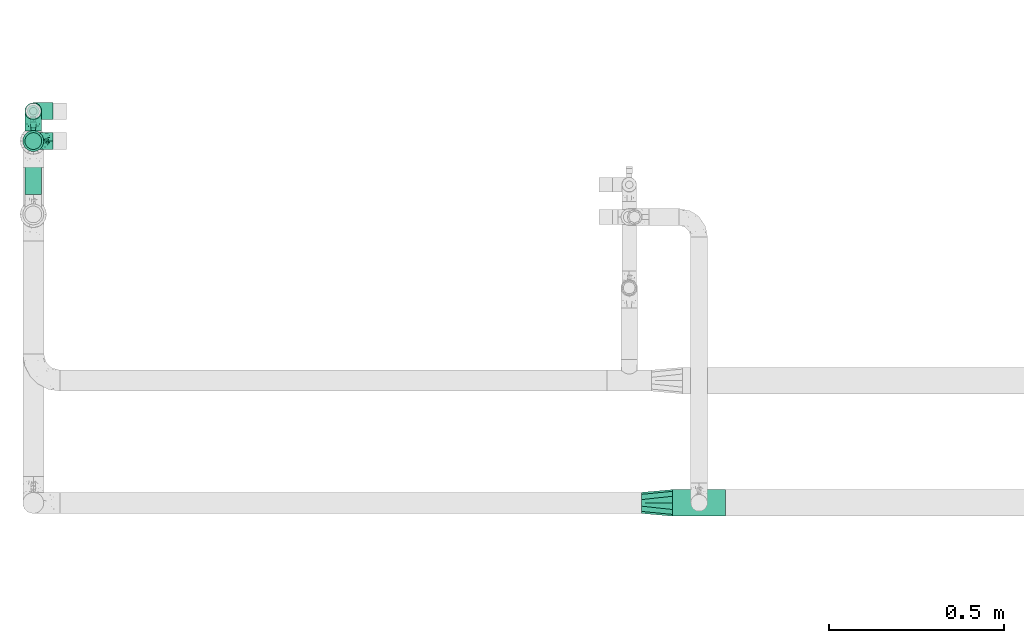
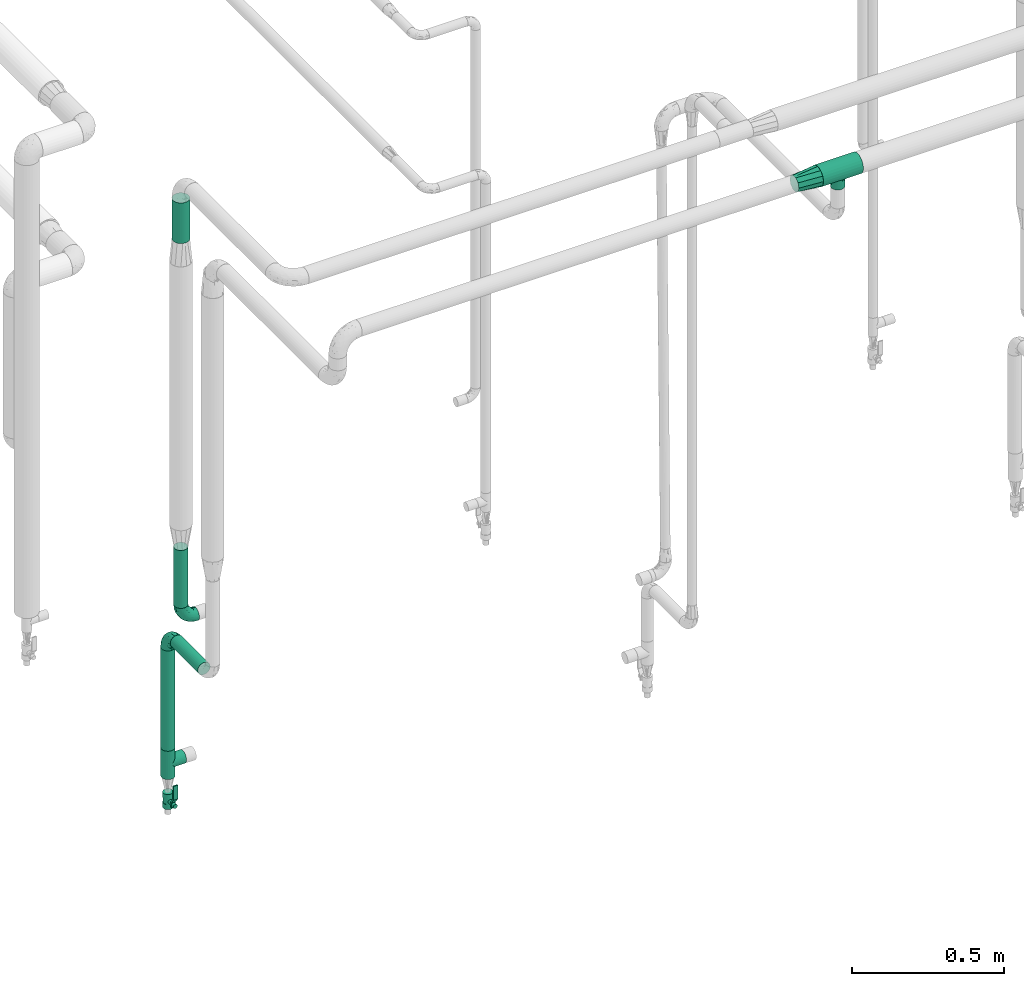
# One storey, part 566 of 827: 5 flow fittings, 4 flow segments, 1 flow controller.
"""IFC2X3 building model written with IfcOpenShell, lengths in millimetres."""

from ifc_helpers import new_model, entity, si_unit, converted_unit, derived_unit, direction, frame, origin, origin_2d_with_axis, place, context, subcontext, project, spatial, polyline, circle, outline, extrude, faceted_brep, source, transform, mapped, material, material_list, type_object, type_shapes, element, save


model = new_model("IFC2X3")

# Units and contexts
model_context = context("Model", 3, precision=0.01, world=origin(), true_north=direction((6.12303176911189e-17, 1.0)))
body_context = subcontext(model_context, "Body", "Model", "MODEL_VIEW")
ifc_project = project(units=[si_unit("LENGTHUNIT", "METRE", prefix="MILLI"), si_unit("AREAUNIT", "SQUARE_METRE"), si_unit("VOLUMEUNIT", "CUBIC_METRE"), converted_unit("PLANEANGLEUNIT", "DEGREE", entity("IfcRatioMeasure", 0.0174532925199433), si_unit("PLANEANGLEUNIT", "RADIAN"), dimensions=[0, 0, 0, 0, 0, 0, 0]), si_unit("MASSUNIT", "GRAM", prefix="KILO"), derived_unit("MASSDENSITYUNIT", [(si_unit("MASSUNIT", "GRAM", prefix="KILO"), 1), (si_unit("LENGTHUNIT", "METRE"), -3)]), derived_unit("MOMENTOFINERTIAUNIT", [(si_unit("LENGTHUNIT", "METRE"), 4)]), si_unit("TIMEUNIT", "SECOND"), si_unit("FREQUENCYUNIT", "HERTZ"), si_unit("THERMODYNAMICTEMPERATUREUNIT", "DEGREE_CELSIUS"), derived_unit("THERMALTRANSMITTANCEUNIT", [(si_unit("MASSUNIT", "GRAM", prefix="KILO"), 1), (si_unit("THERMODYNAMICTEMPERATUREUNIT", "KELVIN"), -1), (si_unit("TIMEUNIT", "SECOND"), -3)]), derived_unit("VOLUMETRICFLOWRATEUNIT", [(si_unit("LENGTHUNIT", "METRE"), 3), (si_unit("TIMEUNIT", "SECOND"), -1)]), derived_unit("MASSFLOWRATEUNIT", [(si_unit("MASSUNIT", "GRAM", prefix="KILO"), 1), (si_unit("TIMEUNIT", "SECOND"), -1)]), derived_unit("ROTATIONALFREQUENCYUNIT", [(si_unit("TIMEUNIT", "SECOND"), -1)]), si_unit("ELECTRICCURRENTUNIT", "AMPERE"), si_unit("ELECTRICVOLTAGEUNIT", "VOLT"), si_unit("POWERUNIT", "WATT"), si_unit("FORCEUNIT", "NEWTON", prefix="KILO"), si_unit("ILLUMINANCEUNIT", "LUX"), si_unit("LUMINOUSFLUXUNIT", "LUMEN"), si_unit("LUMINOUSINTENSITYUNIT", "CANDELA"), derived_unit("USERDEFINED", [(si_unit("MASSUNIT", "GRAM", prefix="KILO"), -1), (si_unit("LENGTHUNIT", "METRE"), -2), (si_unit("TIMEUNIT", "SECOND"), 3), (si_unit("LUMINOUSFLUXUNIT", "LUMEN"), 1)]), derived_unit("LINEARVELOCITYUNIT", [(si_unit("LENGTHUNIT", "METRE"), 1), (si_unit("TIMEUNIT", "SECOND"), -1)]), si_unit("PRESSUREUNIT", "PASCAL"), derived_unit("USERDEFINED", [(si_unit("LENGTHUNIT", "METRE"), -2), (si_unit("MASSUNIT", "GRAM", prefix="KILO"), 1), (si_unit("TIMEUNIT", "SECOND"), -2)]), derived_unit("LINEARFORCEUNIT", [(si_unit("MASSUNIT", "GRAM", prefix="KILO"), 1), (si_unit("LENGTHUNIT", "METRE"), 1), (si_unit("TIMEUNIT", "SECOND"), -2), (si_unit("LENGTHUNIT", "METRE"), -1)]), derived_unit("PLANARFORCEUNIT", [(si_unit("MASSUNIT", "GRAM", prefix="KILO"), 1), (si_unit("LENGTHUNIT", "METRE"), 1), (si_unit("TIMEUNIT", "SECOND"), -2), (si_unit("LENGTHUNIT", "METRE"), -2)])], contexts=[model_context])

# Site, building, storey
site_placement = place(None, origin())
site = spatial("IfcSite", under=ifc_project, at=site_placement, CompositionType="ELEMENT")
building_placement = place(site_placement, origin())
building = spatial("IfcBuilding", under=site, at=building_placement, CompositionType="ELEMENT")
storey_placement = place(building_placement, frame((0.0, 0.0, 28200.0)))
storey = spatial("IfcBuildingStorey", under=building, at=storey_placement, Name="08", CompositionType="ELEMENT", Elevation=28200.0)

# Flow segments
pipe_segment_type = type_object("IfcPipeSegmentType", PredefinedType="NOTDEFINED")
flow_segment_1_placement = place(storey_placement, frame((11725.36, 15495.26, 459.5)))
element("IfcFlowSegment", 1, at=flow_segment_1_placement, inside=storey, type_object=pipe_segment_type, context=body_context, shape_type="SweptSolid", body=[
    extrude(circle(Radius=24.0, at=origin_2d_with_axis()), frame((25.6, 25.6, 0.0), z_axis=(0.0, 0.0, 1.0), x_axis=(-1.0, 0.0, 0.0)), (0.0, 0.0, 1.0), 404.113920389359),
])
flow_segment_2_placement = place(storey_placement, frame((11725.36, 15282.4, 895.02)))
element("IfcFlowSegment", 2, at=flow_segment_2_placement, inside=storey, type_object=pipe_segment_type, context=body_context, shape_type="SweptSolid", body=[
    extrude(circle(Radius=24.0, at=origin_2d_with_axis()), frame((25.6, 0.0, 25.6), z_axis=(0.0, 1.0, 0.0), x_axis=(-1.0, 0.0, 0.0)), (0.0, 0.0, 1.0), 181.457119084471),
])
flow_segment_3_placement = place(storey_placement, frame((11725.36, 15409.61, 1087.0)))
element("IfcFlowSegment", 3, at=flow_segment_3_placement, inside=storey, type_object=pipe_segment_type, context=body_context, shape_type="SweptSolid", body=[
    extrude(circle(Radius=24.0, at=origin_2d_with_axis()), frame((25.6, 25.6, 0.0), z_axis=(0.0, 0.0, 1.0), x_axis=(-1.0, 0.0, 0.0)), (0.0, 0.0, 1.0), 233.163831722912),
])
flow_segment_4_placement = place(storey_placement, frame((11719.36, 15403.61, 2560.7)))
element("IfcFlowSegment", 4, at=flow_segment_4_placement, inside=storey, type_object=pipe_segment_type, context=body_context, shape_type="SweptSolid", body=[
    extrude(circle(Radius=30.0, at=origin_2d_with_axis()), frame((31.6, 31.6, 0.0)), (0.0, 0.0, 1.0), 163.304800928467),
])

# Flow controller
ifc_material = material()
ifc_material_list = material_list([ifc_material, ifc_material, ifc_material, ifc_material, ifc_material])
valve_type = type_object("IfcValveType", PredefinedType="NOTDEFINED", material=ifc_material_list)
shared_shape_1 = source(origin(), body_context, "Body", "SweptSolid", [
    extrude(circle(Radius=17.5, at=origin_2d_with_axis()), frame((-30.5, 0.0, 0.0), z_axis=(1.0, 0.0, 0.0), x_axis=(0.0, 1.0, 0.0)), (0.0, 0.0, 1.0), 20.3333333333333),
    extrude(circle(Radius=16.0, at=origin_2d_with_axis()), frame((-10.17, 0.0, 0.0), z_axis=(1.0, 0.0, 0.0), x_axis=(0.0, 1.0, 0.0)), (0.0, 0.0, 1.0), 20.3333333333333),
    extrude(circle(Radius=17.5, at=origin_2d_with_axis()), frame((10.17, 0.0, 0.0), z_axis=(1.0, 0.0, 0.0), x_axis=(0.0, 1.0, 0.0)), (0.0, 0.0, 1.0), 20.3333333333333),
    extrude(outline(polyline([(-38.75, -5.0), (-38.75, -10.0), (-17.92, -10.0), (2.08, 5.0), (56.25, 5.0), (56.25, 10.0), (0.42, 10.0), (-19.58, -5.0), (-38.75, -5.0)])), frame((28.75, -8.75, 41.5), z_axis=(0.0, -1.0, 0.0), x_axis=(1.0, 0.0, 0.0)), (0.0, 0.0, -1.0), 17.5),
    extrude(circle(Radius=8.0, at=origin_2d_with_axis()), origin(), (0.0, 0.0, 1.0), 49.0),
])
type_shapes(valve_type, [shared_shape_1])
flow_controller_placement = place(storey_placement, frame((11750.95, 15520.86, 250.0), z_axis=(0.0, -1.0, 0.0), x_axis=(0.0, 0.0, 1.0)))
element("IfcFlowController", 5, at=flow_controller_placement, inside=storey, type_object=valve_type, material=ifc_material, context=body_context, shape_type="MappedRepresentation", body=[
    mapped(shared_shape_1, transform((0.0, 0.0, 0.0), scale=1.0)),
])

# Flow fittings
pipe_fitting_type_1 = type_object("IfcPipeFittingType", Name="ADSK_1", PredefinedType="NOTDEFINED", material=ifc_material)
shared_shape_2 = source(origin(), body_context, "Body", "Brep", [
    faceted_brep([(-76.0, 9.85, -36.75), (-76.0, 0.0, -38.05), (-76.0, -9.85, -36.75), (-76.0, -19.03, -32.95), (-76.0, -26.91, -26.91), (-76.0, -32.95, -19.03), (-76.0, -36.75, -9.85), (-76.0, -38.05, 0.0), (-76.0, -36.75, 9.85), (-76.0, -32.95, 19.02), (-76.0, -26.91, 26.91), (-76.0, -19.03, 32.95), (-76.0, -9.85, 36.75), (-76.0, 0.0, 38.05), (-76.0, 9.85, 36.75), (-76.0, 19.02, 32.95), (-76.0, 26.91, 26.91), (-76.0, 32.95, 19.02), (-76.0, 36.75, 9.85), (-76.0, 38.05, 0.0), (-76.0, 36.75, -9.85), (-76.0, 32.95, -19.03), (-76.0, 26.91, -26.91), (-76.0, 19.02, -32.95), (76.0, 26.91, -26.91), (76.0, 32.95, -19.03), (76.0, 36.75, -9.85), (76.0, 38.05, 0.0), (76.0, 36.75, 9.85), (76.0, 32.95, 19.02), (76.0, 26.91, 26.91), (76.0, 19.02, 32.95), (76.0, 9.85, 36.75), (76.0, 0.0, 38.05), (76.0, -9.85, 36.75), (76.0, -19.03, 32.95), (76.0, -26.91, 26.91), (76.0, -32.95, 19.02), (76.0, -36.75, 9.85), (76.0, -38.05, 0.0), (76.0, -36.75, -9.85), (76.0, -32.95, -19.03), (76.0, -26.91, -26.91), (76.0, -19.03, -32.95), (76.0, -9.85, -36.75), (76.0, 0.0, -38.05), (76.0, 9.85, -36.75), (76.0, 19.02, -32.95), (22.62, -37.1, 8.45), (23.39, -37.58, 4.22), (24.15, -38.05, 0.0), (18.42, -34.7, 15.61), (4.31, -29.72, 23.76), (12.18, -31.83, 20.86), (8.24, -30.77, 22.31), (-24.15, -38.05, 0.0), (-23.39, -37.58, 4.22), (-22.63, -37.1, 8.44), (-18.43, -34.7, 15.61), (-12.18, -31.83, 20.85), (-4.31, -29.72, 23.76), (0.0, -29.72, 23.76), (4.31, -29.72, -23.76), (12.18, -31.83, -20.86), (8.24, -30.77, -22.31), (18.42, -34.7, -15.61), (22.62, -37.1, -8.45), (23.39, -37.58, -4.22), (-4.31, -29.72, -23.76), (-12.18, -31.83, -20.85), (-18.43, -34.7, -15.61), (0.0, -29.72, -23.76), (-22.63, -37.1, -8.44), (-23.39, -37.58, -4.22), (0.0, -67.0, -24.15), (6.25, -67.0, -23.33), (12.08, -67.0, -20.91), (17.08, -67.0, -17.08), (20.91, -67.0, -12.08), (23.33, -67.0, -6.25), (24.15, -67.0, 0.0), (23.33, -67.0, 6.25), (20.91, -67.0, 12.07), (17.08, -67.0, 17.08), (12.08, -67.0, 20.91), (6.25, -67.0, 23.33), (0.0, -67.0, 24.15), (-6.25, -67.0, 23.33), (-12.07, -67.0, 20.91), (-17.08, -67.0, 17.08), (-20.91, -67.0, 12.07), (-23.33, -67.0, 6.25), (-24.15, -67.0, 0.0), (-23.33, -67.0, -6.25), (-20.91, -67.0, -12.08), (-17.08, -67.0, -17.08), (-12.07, -67.0, -20.91), (-6.25, -67.0, -23.33)], [[[0, 1, 2, 3, 4, 5, 6, 7, 8, 9, 10, 11, 12, 13, 14, 15, 16, 17, 18, 19, 20, 21, 22, 23]], [[24, 25, 26, 27, 28, 29, 30, 31, 32, 33, 34, 35, 36, 37, 38, 39, 40, 41, 42, 43, 44, 45, 46, 47]], [[39, 38, 48]], [[39, 48, 49, 50]], [[38, 51, 48]], [[37, 36, 52]], [[53, 51, 37]], [[37, 52, 54, 53]], [[36, 10, 52]], [[37, 51, 38]], [[7, 55, 56, 57]], [[8, 7, 57]], [[57, 58, 8]], [[59, 60, 9]], [[59, 9, 58]], [[9, 60, 10]], [[58, 9, 8]], [[10, 60, 61, 52]], [[36, 35, 11, 10]], [[13, 12, 34, 33]], [[12, 11, 35, 34]], [[14, 13, 33, 32]], [[29, 28, 18, 17]], [[16, 15, 31, 30]], [[17, 16, 30, 29]], [[32, 31, 15, 14]], [[19, 18, 28, 27]], [[26, 25, 21, 20]], [[25, 24, 22, 21]], [[27, 26, 20, 19]], [[45, 44, 2, 1]], [[0, 23, 47, 46]], [[1, 0, 46, 45]], [[24, 47, 23, 22]], [[3, 2, 44, 43]], [[43, 42, 4, 3]], [[42, 41, 62]], [[41, 63, 64, 62]], [[41, 65, 63]], [[42, 62, 4]], [[40, 39, 66]], [[66, 65, 40]], [[39, 50, 67, 66]], [[40, 65, 41]], [[68, 69, 5]], [[5, 4, 68]], [[69, 70, 5]], [[4, 62, 71, 68]], [[70, 72, 6]], [[72, 7, 6]], [[7, 72, 73, 55]], [[70, 6, 5]], [[74, 75, 76, 77, 78, 79, 80, 81, 82, 83, 84, 85, 86, 87, 88, 89, 90, 91, 92, 93, 94, 95, 96, 97]], [[56, 92, 91]], [[86, 60, 87]], [[59, 89, 88]], [[84, 54, 85]], [[49, 80, 50]], [[59, 88, 87]], [[49, 48, 81]], [[91, 57, 56]], [[55, 92, 56]], [[57, 91, 90]], [[57, 90, 58]], [[89, 58, 90]], [[89, 59, 58]], [[87, 60, 59]], [[86, 52, 61, 60]], [[84, 53, 54]], [[83, 53, 84]], [[48, 82, 81]], [[83, 82, 51]], [[52, 86, 85]], [[54, 52, 85]], [[53, 83, 51]], [[51, 82, 48]], [[80, 49, 81]], [[79, 67, 80]], [[77, 65, 78]], [[64, 76, 75]], [[79, 66, 67]], [[78, 66, 79]], [[63, 77, 76]], [[67, 50, 80]], [[66, 78, 65]], [[75, 62, 64]], [[63, 65, 77]], [[74, 68, 71, 62]], [[74, 62, 75]], [[73, 92, 55]], [[69, 97, 96]], [[73, 72, 93]], [[95, 69, 96]], [[72, 94, 93]], [[95, 94, 70]], [[68, 74, 97]], [[97, 69, 68]], [[69, 95, 70]], [[70, 94, 72]], [[92, 73, 93]], [[64, 63, 76]]]),
])
type_shapes(pipe_fitting_type_1, [shared_shape_2])
flow_fitting_1_placement = place(storey_placement, frame((13655.95, 14400.0, 2799.96), z_axis=(0.0, -1.0, 0.0), x_axis=(1.0, 0.0, 0.0)))
element("IfcFlowFitting", 6, at=flow_fitting_1_placement, inside=storey, type_object=pipe_fitting_type_1, material=ifc_material, Name="ADSK_1", ObjectType="ADSK_1", context=body_context, shape_type="MappedRepresentation", body=[
    mapped(shared_shape_2, transform((0.0, 0.0, 0.0), scale=1.0)),
])
pipe_fitting_type_2 = type_object("IfcPipeFittingType", Name="ADSK_1", PredefinedType="NOTDEFINED", material=ifc_material)
shared_shape_3 = source(origin(), body_context, "Body", "Brep", [
    faceted_brep([(-57.0, 12.07, -20.91), (-57.0, 6.25, -23.33), (-57.0, 0.0, -24.15), (-57.0, -6.25, -23.33), (-57.0, -12.08, -20.91), (-57.0, -17.08, -17.08), (-57.0, -20.91, -12.08), (-57.0, -23.33, -6.25), (-57.0, -24.15, 0.0), (-57.0, -23.33, 6.25), (-57.0, -20.91, 12.07), (-57.0, -17.08, 17.08), (-57.0, -12.08, 20.91), (-57.0, -6.25, 23.33), (-57.0, 0.0, 24.15), (-57.0, 6.25, 23.33), (-57.0, 12.07, 20.91), (-57.0, 17.08, 17.08), (-57.0, 20.91, 12.07), (-57.0, 23.33, 6.25), (-57.0, 24.15, 0.0), (-57.0, 23.33, -6.25), (-57.0, 20.91, -12.08), (-57.0, 17.08, -17.08), (0.0, 57.0, -24.15), (-6.25, 57.0, -23.33), (-12.07, 57.0, -20.91), (-17.08, 57.0, -17.08), (-20.91, 57.0, -12.08), (-23.33, 57.0, -6.25), (-24.15, 57.0, 0.0), (-23.33, 57.0, 6.25), (-20.91, 57.0, 12.07), (-17.08, 57.0, 17.08), (-12.07, 57.0, 20.91), (-6.25, 57.0, 23.33), (0.0, 57.0, 24.15), (6.25, 57.0, 23.33), (12.08, 57.0, 20.91), (17.08, 57.0, 17.08), (20.91, 57.0, 12.07), (23.33, 57.0, 6.25), (24.15, 57.0, 0.0), (23.33, 57.0, -6.25), (20.91, 57.0, -12.08), (17.08, 57.0, -17.08), (12.08, 57.0, -20.91), (6.25, 57.0, -23.33), (14.9, 21.14, 6.17), (13.61, 24.64, 12.48), (6.23, 8.95, 8.98), (-41.47, -21.06, 0.0), (-41.92, -18.38, 13.72), (-24.64, -13.61, 12.48), (-37.37, -13.24, 18.15), (-6.8, -4.93, 8.18), (-21.76, -15.19, 6.22), (-12.78, -9.18, 0.0), (-37.73, -20.51, 7.75), (-7.38, 7.38, 20.24), (-23.37, -4.26, 20.42), (-11.9, -3.19, 15.86), (-42.14, -8.7, 21.82), (13.24, 37.37, 18.15), (9.33, 23.53, 16.85), (4.26, 23.37, 20.42), (2.77, 10.92, 15.55), (-29.46, 0.91, 23.52), (-44.13, 20.56, 15.69), (-39.25, 26.33, 10.88), (-49.02, 22.92, 9.96), (-34.58, 23.87, 17.15), (-15.8, 6.8, 22.81), (-8.67, 20.47, 23.88), (-18.12, 12.9, 24.08), (-48.29, 14.92, 19.65), (-44.06, -2.85, 23.78), (-9.23, 48.95, 22.58), (-3.78, 42.74, 24.07), (-40.34, 4.26, 24.09), (-44.02, 26.14, 5.46), (-44.04, 9.88, 22.74), (-4.95, 16.87, 22.52), (-2.75, 1.43, 12.5), (-25.48, 40.98, 10.71), (20.51, 37.73, 7.75), (18.38, 41.92, 13.72), (8.7, 42.14, 21.82), (-25.95, -17.97, 0.0), (2.85, 44.06, 23.78), (21.06, 41.47, 0.0), (17.97, 25.95, 0.0), (-24.04, -9.27, 17.13), (-33.26, 33.26, 5.86), (-28.55, 40.57, 0.0), (-40.57, 28.55, 0.0), (-25.29, 47.19, 4.06), (-27.01, 31.1, 16.77), (-15.7, 43.95, 19.9), (-20.27, 45.22, 15.61), (-30.53, 31.98, 12.64), (-11.28, 38.33, 22.92), (-9.97, 27.88, 24.09), (-20.15, 30.26, 21.25), (-31.25, 11.75, 23.64), (-28.75, 7.23, 24.15), (-29.53, 18.06, 22.27), (-28.44, 24.21, 20.02), (-37.55, 17.7, 20.26), (-15.88, 29.25, 22.99), (-20.82, 20.82, 23.44), (-0.91, 29.46, 23.52), (-13.5, -7.67, 12.04), (1.49, 1.56, 5.16), (8.86, 10.35, 4.59), (0.38, -0.38, 0.0), (9.18, 12.78, 0.0), (-37.37, -13.24, -18.15), (8.86, 10.35, -4.59), (-45.22, 20.27, -15.61), (-43.95, 15.7, -19.9), (-38.33, 11.28, -22.92), (-48.95, 9.23, -22.58), (-47.19, 25.29, -4.06), (-33.26, 33.26, -5.86), (18.38, 41.92, -13.72), (-30.26, 20.15, -21.25), (2.85, 44.06, -23.78), (-4.26, 40.34, -24.09), (-40.98, 25.48, -10.71), (-41.92, -18.38, -13.72), (9.25, 23.5, -16.92), (4.26, 23.37, -20.42), (13.24, 37.37, -18.15), (-37.73, -20.51, -7.75), (-11.75, 31.25, -23.64), (-7.23, 28.75, -24.15), (-12.9, 18.12, -24.08), (8.7, 42.14, -21.82), (-44.06, -2.85, -23.78), (-6.8, 15.8, -22.81), (-20.47, 8.67, -23.88), (-24.64, -13.61, -12.48), (-42.74, 3.78, -24.07), (-18.06, 29.53, -22.27), (-24.21, 28.44, -20.02), (-27.88, 9.97, -24.09), (-31.1, 27.01, -16.77), (-26.14, 44.02, -5.46), (14.9, 21.14, -6.17), (20.51, 37.73, -7.75), (-9.88, 44.04, -22.74), (-20.56, 44.13, -15.69), (-21.76, -15.19, -6.22), (-13.5, -7.67, -12.04), (-24.14, -9.76, -16.74), (-11.9, -3.19, -15.86), (-14.92, 48.29, -19.65), (-23.37, -4.26, -20.42), (-0.91, 29.46, -23.52), (-26.33, 39.25, -10.88), (-23.87, 34.58, -17.15), (-42.14, -8.7, -21.82), (-22.92, 49.02, -9.96), (13.61, 24.64, -12.48), (-31.98, 30.53, -12.64), (-16.87, 4.95, -22.52), (-17.7, 37.55, -20.26), (-29.25, 15.88, -22.99), (-20.82, 20.82, -23.44), (-29.46, 0.91, -23.52), (-7.38, 7.38, -20.24), (2.77, 10.92, -15.55), (6.23, 8.95, -8.98), (-6.8, -4.93, -8.18), (-2.81, 1.41, -12.54), (1.49, 1.56, -5.16)], [[[0, 1, 2, 3, 4, 5, 6, 7, 8, 9, 10, 11, 12, 13, 14, 15, 16, 17, 18, 19, 20, 21, 22, 23]], [[24, 25, 26, 27, 28, 29, 30, 31, 32, 33, 34, 35, 36, 37, 38, 39, 40, 41, 42, 43, 44, 45, 46, 47]], [[48, 49, 50]], [[9, 8, 51]], [[52, 53, 54]], [[55, 56, 57]], [[10, 58, 52]], [[9, 58, 10]], [[59, 60, 61]], [[54, 12, 11]], [[54, 62, 12]], [[63, 39, 38]], [[64, 65, 66]], [[62, 60, 67]], [[68, 69, 70]], [[71, 69, 68]], [[72, 73, 74]], [[16, 75, 17]], [[13, 76, 14]], [[35, 77, 78]], [[14, 79, 15]], [[17, 68, 18]], [[14, 76, 79]], [[20, 19, 80]], [[70, 19, 18]], [[81, 15, 79]], [[15, 81, 16]], [[73, 72, 82]], [[66, 83, 50]], [[32, 31, 84]], [[85, 86, 49]], [[63, 87, 65]], [[56, 58, 88]], [[36, 89, 37]], [[85, 41, 40]], [[36, 35, 78]], [[90, 41, 85]], [[40, 39, 86]], [[12, 62, 13]], [[86, 85, 40]], [[48, 85, 49]], [[85, 91, 90]], [[87, 38, 37]], [[92, 60, 54]], [[80, 69, 93]], [[93, 94, 95]], [[10, 52, 11]], [[94, 96, 30]], [[97, 98, 99]], [[80, 93, 95]], [[100, 97, 84]], [[99, 98, 33]], [[101, 102, 78]], [[103, 101, 98]], [[96, 31, 30]], [[77, 98, 101]], [[77, 35, 34]], [[34, 33, 98]], [[9, 51, 58]], [[87, 63, 38]], [[104, 105, 74]], [[106, 103, 107]], [[106, 81, 104]], [[75, 68, 17]], [[108, 107, 71]], [[33, 32, 99]], [[109, 103, 110]], [[101, 109, 102]], [[89, 78, 111]], [[53, 52, 58]], [[54, 11, 52]], [[60, 62, 54]], [[88, 58, 51]], [[76, 62, 67]], [[53, 112, 92]], [[60, 59, 72]], [[39, 63, 86]], [[49, 86, 63]], [[89, 87, 37]], [[42, 41, 90]], [[111, 82, 65]], [[111, 65, 87]], [[65, 59, 66]], [[104, 81, 79]], [[75, 81, 108]], [[32, 84, 99]], [[97, 99, 84]], [[98, 97, 103]], [[106, 107, 108]], [[74, 102, 110]], [[111, 78, 102]], [[74, 110, 104]], [[74, 67, 72]], [[61, 92, 112]], [[66, 59, 61]], [[56, 53, 58]], [[66, 50, 49]], [[61, 112, 83]], [[66, 49, 64]], [[78, 89, 36]], [[87, 89, 111]], [[62, 76, 13]], [[79, 76, 67]], [[100, 93, 69]], [[96, 93, 84]], [[55, 113, 50]], [[113, 114, 50]], [[104, 79, 105]], [[106, 104, 110]], [[20, 80, 95]], [[85, 48, 91]], [[115, 114, 113]], [[116, 91, 48]], [[70, 80, 19]], [[93, 96, 94]], [[84, 31, 96]], [[103, 106, 110]], [[81, 106, 108]], [[103, 97, 107]], [[71, 107, 97]], [[71, 97, 100]], [[108, 71, 68]], [[79, 67, 105]], [[67, 74, 105]], [[115, 113, 57]], [[112, 56, 55]], [[56, 88, 57]], [[60, 72, 67]], [[82, 72, 59]], [[65, 82, 59]], [[82, 111, 73]], [[111, 102, 73]], [[102, 74, 73]], [[81, 75, 16]], [[68, 75, 108]], [[68, 70, 18]], [[80, 70, 69]], [[98, 77, 34]], [[78, 77, 101]], [[93, 100, 84]], [[71, 100, 69]], [[102, 109, 110]], [[101, 103, 109]], [[53, 92, 54]], [[61, 60, 92]], [[56, 112, 53]], [[83, 112, 55]], [[50, 83, 55]], [[61, 83, 66]], [[49, 63, 64]], [[65, 64, 63]], [[57, 113, 55]], [[114, 115, 116]], [[116, 48, 114]], [[48, 50, 114]], [[117, 5, 4]], [[116, 115, 118]], [[119, 120, 23]], [[121, 122, 120]], [[95, 123, 20]], [[0, 23, 120]], [[124, 95, 94]], [[125, 45, 44]], [[121, 120, 126]], [[24, 127, 128]], [[22, 21, 129]], [[0, 122, 1]], [[5, 117, 130]], [[131, 132, 133]], [[134, 88, 51]], [[135, 136, 137]], [[6, 5, 130]], [[46, 138, 47]], [[139, 3, 2]], [[140, 141, 137]], [[6, 134, 7]], [[134, 130, 142]], [[143, 2, 1]], [[144, 126, 145]], [[121, 146, 143]], [[147, 120, 119]], [[94, 148, 124]], [[149, 150, 91]], [[30, 29, 148]], [[151, 25, 128]], [[27, 152, 28]], [[134, 153, 88]], [[154, 155, 156]], [[27, 26, 157]], [[151, 26, 25]], [[155, 158, 156]], [[24, 47, 127]], [[1, 122, 143]], [[138, 132, 159]], [[160, 152, 161]], [[24, 128, 25]], [[46, 133, 138]], [[162, 117, 4]], [[148, 160, 124]], [[152, 160, 163]], [[154, 142, 155]], [[45, 125, 133]], [[133, 46, 45]], [[125, 164, 133]], [[51, 7, 134]], [[42, 90, 43]], [[165, 147, 129]], [[153, 134, 142]], [[43, 150, 44]], [[162, 4, 3]], [[141, 140, 166]], [[117, 162, 158]], [[163, 29, 28]], [[43, 90, 150]], [[123, 21, 20]], [[144, 151, 135]], [[157, 152, 27]], [[167, 145, 161]], [[23, 22, 119]], [[168, 126, 169]], [[121, 168, 146]], [[139, 143, 170]], [[142, 130, 117]], [[8, 7, 51]], [[134, 6, 130]], [[139, 162, 3]], [[170, 166, 158]], [[170, 158, 162]], [[158, 171, 156]], [[44, 150, 125]], [[91, 150, 90]], [[164, 125, 150]], [[132, 138, 133]], [[127, 138, 159]], [[131, 164, 172]], [[132, 171, 140]], [[135, 151, 128]], [[157, 151, 167]], [[22, 129, 119]], [[147, 119, 129]], [[120, 147, 126]], [[144, 145, 167]], [[137, 146, 169]], [[170, 143, 146]], [[137, 169, 135]], [[137, 159, 140]], [[171, 172, 156]], [[173, 174, 175]], [[156, 175, 154]], [[174, 57, 153]], [[132, 172, 171]], [[172, 164, 173]], [[143, 139, 2]], [[162, 139, 170]], [[138, 127, 47]], [[128, 127, 159]], [[165, 124, 160]], [[123, 124, 129]], [[149, 173, 164]], [[176, 174, 173]], [[135, 128, 136]], [[144, 135, 169]], [[150, 149, 164]], [[176, 118, 115]], [[149, 91, 116]], [[30, 148, 94]], [[163, 148, 29]], [[124, 123, 95]], [[129, 21, 123]], [[126, 144, 169]], [[151, 144, 167]], [[126, 147, 145]], [[161, 145, 147]], [[161, 147, 165]], [[167, 161, 152]], [[128, 159, 136]], [[159, 137, 136]], [[154, 153, 142]], [[132, 140, 159]], [[174, 176, 57]], [[57, 88, 153]], [[166, 140, 171]], [[158, 166, 171]], [[166, 170, 141]], [[170, 146, 141]], [[146, 137, 141]], [[151, 157, 26]], [[152, 157, 167]], [[152, 163, 28]], [[148, 163, 160]], [[120, 122, 0]], [[143, 122, 121]], [[124, 165, 129]], [[161, 165, 160]], [[146, 168, 169]], [[121, 126, 168]], [[142, 117, 155]], [[158, 155, 117]], [[175, 156, 172]], [[153, 154, 174]], [[173, 175, 172]], [[174, 154, 175]], [[164, 131, 133]], [[172, 132, 131]], [[176, 173, 118]], [[57, 176, 115]], [[173, 149, 118]], [[149, 116, 118]]]),
])
type_shapes(pipe_fitting_type_2, [shared_shape_3])
for number, where, z_axis, x_axis, name in (
    (7, (11750.95, 15520.86, 920.61), (1.0, 0.0, 0.0), (0.0, 0.0, 1.0), "ADSK_1"),
    (8, (11750.95, 15435.21, 1030.0), (0.0, -1.0, 0.0), (0.0, 0.0, -1.0), "ADSK_1"),
):
    element("IfcFlowFitting", number, at=place(storey_placement, frame(where, z_axis=z_axis, x_axis=x_axis)), inside=storey, type_object=pipe_fitting_type_2, material=ifc_material, Name=name, ObjectType="ADSK_1", context=body_context, shape_type="MappedRepresentation", body=[
        mapped(shared_shape_3, transform((0.0, 0.0, 0.0), scale=1.0)),
    ])
pipe_fitting_type_3 = type_object("IfcPipeFittingType", Name="ADSK_1", PredefinedType="NOTDEFINED", material=ifc_material)
shared_shape_4 = source(origin(), body_context, "Body", "Brep", [
    faceted_brep([(-57.0, 12.07, -20.91), (-57.0, 6.25, -23.33), (-57.0, 0.0, -24.15), (-57.0, -6.25, -23.33), (-57.0, -12.08, -20.91), (-57.0, -17.08, -17.08), (-57.0, -20.91, -12.08), (-57.0, -23.33, -6.25), (-57.0, -24.15, 0.0), (-57.0, -23.33, 6.25), (-57.0, -20.91, 12.07), (-57.0, -17.08, 17.08), (-57.0, -12.08, 20.91), (-57.0, -6.25, 23.33), (-57.0, 0.0, 24.15), (-57.0, 6.25, 23.33), (-57.0, 12.07, 20.91), (-57.0, 17.08, 17.08), (-57.0, 20.91, 12.07), (-57.0, 23.33, 6.25), (-57.0, 24.15, 0.0), (-57.0, 23.33, -6.25), (-57.0, 20.91, -12.08), (-57.0, 17.08, -17.08), (57.0, 0.0, -24.15), (57.0, 6.25, -23.33), (57.0, 12.07, -20.91), (57.0, 17.08, -17.08), (57.0, 20.91, -12.08), (57.0, 23.33, -6.25), (57.0, 24.15, 0.0), (57.0, 23.33, 6.25), (57.0, 20.91, 12.07), (57.0, 17.08, 17.08), (57.0, 12.07, 20.91), (57.0, 6.25, 23.33), (57.0, 0.0, 24.15), (57.0, -6.25, 23.33), (57.0, -12.08, 20.91), (57.0, -17.08, 17.08), (57.0, -20.91, 12.07), (57.0, -23.33, 6.25), (57.0, -24.15, 0.0), (57.0, -23.33, -6.25), (57.0, -20.91, -12.08), (57.0, -17.08, -17.08), (57.0, -12.08, -20.91), (57.0, -6.25, -23.33), (23.27, -23.27, 6.45), (24.15, -24.15, 0.0), (-24.15, -24.15, 0.0), (20.9, -20.9, 12.1), (13.54, -13.54, 20.0), (17.52, -17.52, 16.62), (-23.27, -23.27, 6.45), (-20.9, -20.9, 12.1), (-17.52, -17.52, 16.62), (-13.54, -13.54, 20.0), (-9.19, -9.19, 22.33), (9.19, -9.19, 22.33), (4.64, -4.64, 23.7), (0.0, 0.0, 24.15), (-4.64, -4.64, 23.7), (4.64, -4.64, -23.7), (0.0, 0.0, -24.15), (-4.64, -4.64, -23.7), (-9.19, -9.19, -22.33), (9.19, -9.19, -22.33), (13.54, -13.54, -20.0), (17.52, -17.52, -16.62), (20.9, -20.9, -12.1), (23.27, -23.27, -6.45), (-13.54, -13.54, -20.0), (-17.52, -17.52, -16.62), (-23.27, -23.27, -6.45), (-20.9, -20.9, -12.1), (0.0, -57.0, -24.15), (6.25, -57.0, -23.33), (12.08, -57.0, -20.91), (17.08, -57.0, -17.08), (20.91, -57.0, -12.08), (23.33, -57.0, -6.25), (24.15, -57.0, 0.0), (23.33, -57.0, 6.25), (20.91, -57.0, 12.07), (17.08, -57.0, 17.08), (12.08, -57.0, 20.91), (6.25, -57.0, 23.33), (0.0, -57.0, 24.15), (-6.25, -57.0, 23.33), (-12.07, -57.0, 20.91), (-17.08, -57.0, 17.08), (-20.91, -57.0, 12.07), (-23.33, -57.0, 6.25), (-24.15, -57.0, 0.0), (-23.33, -57.0, -6.25), (-20.91, -57.0, -12.08), (-17.08, -57.0, -17.08), (-12.07, -57.0, -20.91), (-6.25, -57.0, -23.33)], [[[0, 1, 2, 3, 4, 5, 6, 7, 8, 9, 10, 11, 12, 13, 14, 15, 16, 17, 18, 19, 20, 21, 22, 23]], [[24, 25, 26, 27, 28, 29, 30, 31, 32, 33, 34, 35, 36, 37, 38, 39, 40, 41, 42, 43, 44, 45, 46, 47]], [[41, 40, 48]], [[42, 41, 49]], [[50, 9, 8]], [[49, 41, 48]], [[40, 51, 48]], [[39, 38, 52]], [[51, 40, 53]], [[52, 53, 39]], [[53, 40, 39]], [[50, 54, 9]], [[9, 54, 10]], [[54, 55, 10]], [[56, 57, 11]], [[11, 10, 56]], [[11, 57, 12]], [[56, 10, 55]], [[12, 57, 58]], [[52, 38, 59]], [[60, 36, 61]], [[62, 61, 14]], [[59, 37, 60]], [[37, 59, 38]], [[60, 37, 36]], [[61, 36, 35, 15, 14]], [[32, 31, 19, 18]], [[17, 16, 34, 33]], [[18, 17, 33, 32]], [[35, 34, 16, 15]], [[20, 19, 31, 30]], [[62, 13, 58]], [[13, 62, 14]], [[58, 13, 12]], [[27, 23, 22, 28]], [[22, 21, 29, 28]], [[0, 23, 27, 26]], [[20, 30, 29, 21]], [[24, 47, 63]], [[24, 64, 2, 1, 25]], [[64, 24, 63]], [[2, 64, 65]], [[26, 25, 1, 0]], [[65, 66, 3]], [[2, 65, 3]], [[66, 4, 3]], [[63, 47, 67]], [[46, 45, 68]], [[69, 68, 45]], [[44, 70, 69]], [[69, 45, 44]], [[46, 68, 67]], [[43, 42, 49]], [[7, 50, 8]], [[43, 71, 44]], [[71, 43, 49]], [[44, 71, 70]], [[72, 4, 66]], [[72, 5, 4]], [[5, 72, 73]], [[5, 73, 6]], [[74, 50, 7]], [[75, 74, 6]], [[74, 7, 6]], [[75, 6, 73]], [[46, 67, 47]], [[76, 77, 78, 79, 80, 81, 82, 83, 84, 85, 86, 87, 88, 89, 90, 91, 92, 93, 94, 95, 96, 97, 98, 99]], [[50, 94, 93]], [[54, 50, 93]], [[91, 90, 57]], [[56, 92, 91]], [[54, 93, 92]], [[58, 90, 89]], [[55, 54, 92]], [[56, 55, 92]], [[58, 57, 90]], [[88, 61, 62]], [[58, 89, 62]], [[56, 91, 57]], [[62, 89, 88]], [[60, 88, 87]], [[86, 59, 87]], [[84, 83, 48]], [[53, 85, 84]], [[52, 86, 85]], [[49, 83, 82]], [[59, 60, 87]], [[52, 59, 86]], [[49, 48, 83]], [[51, 53, 84]], [[48, 51, 84]], [[52, 85, 53]], [[88, 60, 61]], [[82, 81, 49]], [[71, 49, 81]], [[69, 80, 79]], [[79, 78, 68]], [[71, 81, 80]], [[67, 78, 77]], [[70, 71, 80]], [[69, 70, 80]], [[67, 68, 78]], [[76, 64, 63]], [[67, 77, 63]], [[69, 79, 68]], [[63, 77, 76]], [[65, 76, 99]], [[98, 66, 99]], [[96, 95, 74]], [[73, 97, 96]], [[72, 98, 97]], [[50, 95, 94]], [[66, 65, 99]], [[72, 66, 98]], [[50, 74, 95]], [[75, 73, 96]], [[74, 75, 96]], [[72, 97, 73]], [[76, 65, 64]]]),
])
type_shapes(pipe_fitting_type_3, [shared_shape_4])
flow_fitting_2_placement = place(storey_placement, frame((11750.95, 15520.86, 402.5), z_axis=(0.0, -1.0, 0.0), x_axis=(0.0, 0.0, 1.0)))
element("IfcFlowFitting", 9, at=flow_fitting_2_placement, inside=storey, type_object=pipe_fitting_type_3, material=ifc_material, Name="ADSK_1", ObjectType="ADSK_1", context=body_context, shape_type="MappedRepresentation", body=[
    mapped(shared_shape_4, transform((0.0, 0.0, 0.0), scale=1.0)),
])
pipe_fitting_type_4 = type_object("IfcPipeFittingType", Name="ADSK_1", PredefinedType="NOTDEFINED", material=ifc_material)
shared_shape_5 = source(origin(), body_context, "Body", "Brep", [
    faceted_brep([(89.0, 32.95, -19.02), (89.0, 36.11, -7.24), (89.0, 38.05, 0.0), (89.0, 36.11, 7.24), (89.0, 32.95, 19.03), (89.0, 25.99, 25.99), (89.0, 19.02, 32.95), (89.0, 9.51, 35.5), (89.0, 0.0, 38.05), (89.0, -9.51, 35.5), (89.0, -19.03, 32.95), (89.0, -25.99, 25.99), (89.0, -32.95, 19.03), (89.0, -36.11, 7.24), (89.0, -38.05, 0.0), (89.0, -36.11, -7.24), (89.0, -32.95, -19.02), (89.0, -25.99, -25.99), (89.0, -19.03, -32.95), (89.0, -9.51, -35.5), (89.0, 0.0, -38.05), (89.0, 9.51, -35.5), (89.0, 19.02, -32.95), (89.0, 25.99, -25.99), (0.0, 30.15, 0.0), (0.0, 27.27, -8.86), (0.0, 24.39, -17.72), (0.0, 16.85, -23.2), (0.0, 9.32, -28.67), (0.0, 0.0, -28.67), (0.0, -9.32, -28.67), (0.0, -16.85, -23.2), (0.0, -24.39, -17.72), (0.0, -27.27, -8.86), (0.0, -30.15, 0.0), (0.0, -27.27, 8.86), (0.0, -24.39, 17.72), (0.0, -16.85, 23.2), (0.0, -9.32, 28.67), (0.0, 0.0, 28.67), (0.0, 9.32, 28.67), (0.0, 16.85, 23.2), (0.0, 24.39, 17.72), (0.0, 27.27, 8.86)], [[[0, 1, 2, 3, 4, 5, 6, 7, 8, 9, 10, 11, 12, 13, 14, 15, 16, 17, 18, 19, 20, 21, 22, 23]], [[24, 25, 26, 27, 28, 29, 30, 31, 32, 33, 34, 35, 36, 37, 38, 39, 40, 41, 42, 43]], [[16, 33, 32]], [[28, 21, 29]], [[29, 19, 30]], [[19, 18, 30]], [[17, 32, 31]], [[34, 15, 14]], [[15, 34, 33]], [[22, 28, 27]], [[16, 15, 33]], [[0, 25, 1]], [[31, 30, 18]], [[1, 25, 24]], [[26, 0, 23]], [[24, 2, 1]], [[28, 22, 21]], [[16, 32, 17]], [[27, 26, 23]], [[26, 25, 0]], [[31, 18, 17]], [[22, 27, 23]], [[29, 21, 20]], [[19, 29, 20]], [[4, 43, 42]], [[38, 9, 39]], [[39, 7, 40]], [[7, 6, 40]], [[5, 42, 41]], [[24, 3, 2]], [[3, 24, 43]], [[10, 38, 37]], [[4, 3, 43]], [[12, 35, 13]], [[41, 40, 6]], [[13, 35, 34]], [[36, 12, 11]], [[34, 14, 13]], [[38, 10, 9]], [[4, 42, 5]], [[37, 36, 11]], [[36, 35, 12]], [[41, 6, 5]], [[10, 37, 11]], [[39, 9, 8]], [[7, 39, 8]]]),
])
type_shapes(pipe_fitting_type_4, [shared_shape_5])
flow_fitting_3_placement = place(storey_placement, frame((13490.95, 14400.0, 2799.96)))
element("IfcFlowFitting", 10, at=flow_fitting_3_placement, inside=storey, type_object=pipe_fitting_type_4, material=ifc_material, Name="ADSK_1", ObjectType="ADSK_1", context=body_context, shape_type="MappedRepresentation", body=[
    mapped(shared_shape_5, transform((0.0, 0.0, 0.0), scale=1.0)),
])

save(model, "model.ifc")
